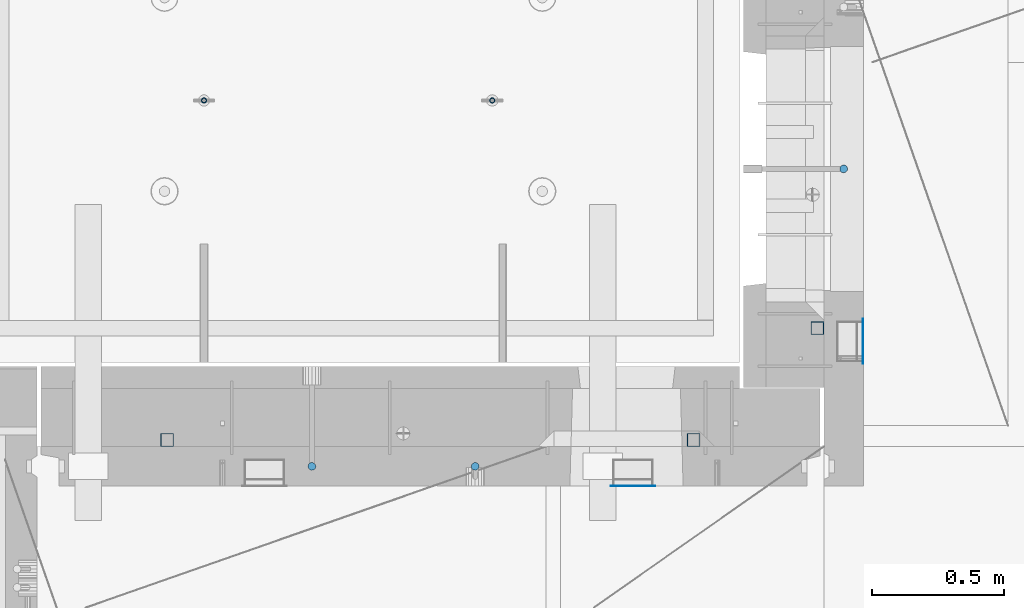
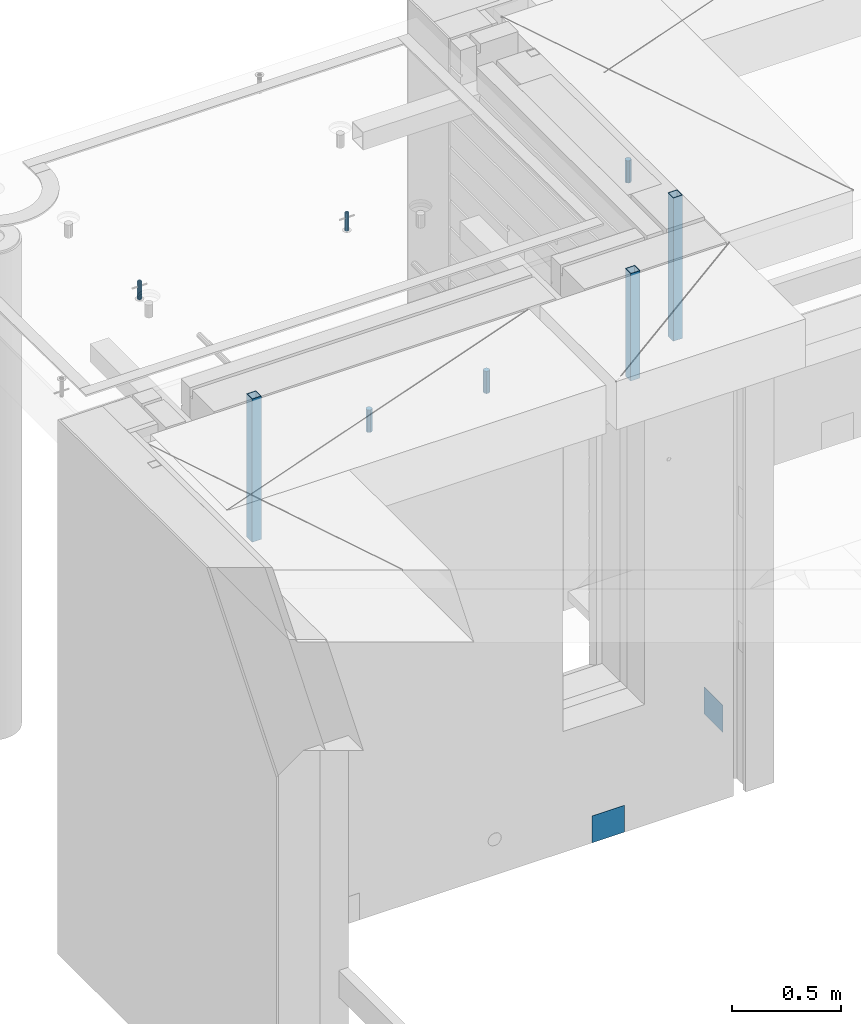
# One storey, part 25 of 334: 10 columns, 10 elements without a shape of their own.
"""IFC2X3 building model written with IfcOpenShell, lengths in millimetres."""

import ifcopenshell
import ifcopenshell.guid

model = None  # the IFC model being written
_history = None  # IfcOwnerHistory: only IFC2X3 demands one
_inside = {}  # id of a spatial element -> (the spatial element, [elements in it])
_under = {}  # id of a project, library or spatial element -> (it, [spatial elements below it])
_declared = {}  # id of a project -> (the project, [libraries it declares])
_typed = {}  # id of a type object -> (the type object, [elements of that type])
_made_of = {}  # id of a material, layer set ... -> (it, [elements and type objects made of it])


def new_model(schema):
    """Start an empty IFC model of exactly this schema.

    Asked for "IFC4X3", IfcOpenShell would pick the latest addendum, in which some entities
    have other attributes; the version numbers below select the first issue.
    IFC2X3 requires an IfcOwnerHistory on every rooted entity: one is made here for all.
    """
    global model, _history
    if schema == "IFC4X3":
        model = ifcopenshell.file(schema_version=(4, 3, 0, 0))
    else:
        model = ifcopenshell.file(schema=schema)
    _inside.clear()
    _under.clear()
    _declared.clear()
    _typed.clear()
    _made_of.clear()
    _history = None
    if model.schema == "IFC2X3":
        org = make("IfcOrganization", Name="unknown")
        user = make(
            "IfcPersonAndOrganization",
            ThePerson=make("IfcPerson", FamilyName="unknown"),
            TheOrganization=org,
        )
        app = make(
            "IfcApplication",
            ApplicationDeveloper=org,
            Version="unknown",
            ApplicationFullName="unknown",
            ApplicationIdentifier="unknown",
        )
        _history = make(
            "IfcOwnerHistory",
            OwningUser=user,
            OwningApplication=app,
            ChangeAction="ADDED",
            CreationDate=0,
        )
    return model


def make(cls, **values):
    """One entity of the class cls with the attributes given. An attribute that is None is left unset."""
    return model.create_entity(
        cls, **{name: value for name, value in values.items() if value is not None}
    )


def rooted(cls, **values):
    """An entity with a GlobalId (a new one), such as an element, a storey or a relation."""
    return make(cls, GlobalId=ifcopenshell.guid.new(), OwnerHistory=_history, **values)


def si_unit(unit_type, name, prefix=None):
    """IfcSIUnit, for example si_unit("LENGTHUNIT", "METRE", prefix="MILLI")."""
    return make("IfcSIUnit", UnitType=unit_type, Prefix=prefix, Name=name)


def assignment(units):
    """IfcUnitAssignment: the units of a project."""
    return None if units is None else make("IfcUnitAssignment", Units=units)


def point(xyz):
    """IfcCartesianPoint."""
    return None if xyz is None else make("IfcCartesianPoint", Coordinates=xyz)


def direction(xyz):
    """IfcDirection."""
    return None if xyz is None else make("IfcDirection", DirectionRatios=xyz)


def frame(location, z_axis=None, x_axis=None):
    """IfcAxis2Placement3D, a coordinate frame: its origin and axes. An axis left out is left unset."""
    return make(
        "IfcAxis2Placement3D",
        Location=point(location),
        Axis=direction(z_axis),
        RefDirection=direction(x_axis),
    )


def origin_with_axes():
    """The frame at (0, 0, 0) with the z axis (0, 0, 1) and the x axis (1, 0, 0) written out."""
    return frame((0.0, 0.0, 0.0), z_axis=(0.0, 0.0, 1.0), x_axis=(1.0, 0.0, 0.0))


def place(relative_to, where):
    """IfcLocalPlacement: puts the frame where relative to a parent placement (None: the world)."""
    return make(
        "IfcLocalPlacement", PlacementRelTo=relative_to, RelativePlacement=where
    )


def context(
    kind, dimensions, precision=None, world=None, true_north=None, identifier=None
):
    """IfcGeometricRepresentationContext, for example the 3D "Model" context."""
    return make(
        "IfcGeometricRepresentationContext",
        ContextIdentifier=identifier,
        ContextType=kind,
        CoordinateSpaceDimension=dimensions,
        Precision=precision,
        WorldCoordinateSystem=world,
        TrueNorth=true_north,
    )


def subcontext(parent, identifier, kind, view, scale=None):
    """IfcGeometricRepresentationSubContext, for example "Body" below "Model"."""
    return make(
        "IfcGeometricRepresentationSubContext",
        ContextIdentifier=identifier,
        ContextType=kind,
        ParentContext=parent,
        TargetScale=scale,
        TargetView=view,
    )


def project(units=None, contexts=None):
    """IfcProject with its units and contexts."""
    return rooted(
        "IfcProject",
        Name="project",
        RepresentationContexts=contexts,
        UnitsInContext=assignment(units),
    )


def spatial(cls, under=None, at=None, **own):
    """A site, building, storey or space (cls), placed at a placement, below another one or the project."""
    s = rooted(cls, ObjectPlacement=at, **own)
    if under is not None:
        _under.setdefault(under.id(), (under, []))[1].append(s)
    return s


def faces_of(points, faces, orient=None, outer=None):
    """IfcFace entities. A face is a list of loops; a loop is a list of indices into points, from 0.

    orient and outer hold one flag for each loop. By default every Orientation is true, the
    first loop of a face is its IfcFaceOuterBound and the others are IfcFaceBound.
    """
    made = []
    for i, loops in enumerate(faces):
        bounds = []
        for j, loop in enumerate(loops):
            is_outer = j == 0 if outer is None else outer[i][j]
            bounds.append(
                make(
                    "IfcFaceOuterBound" if is_outer else "IfcFaceBound",
                    Bound=make("IfcPolyLoop", Polygon=[points[k] for k in loop]),
                    Orientation=True if orient is None else orient[i][j],
                )
            )
        made.append(make("IfcFace", Bounds=bounds))
    return made


def faceted_brep(points, faces, orient=None, outer=None, voids=None):
    """IfcFacetedBrep: a solid bounded by flat faces; with voids (closed shells), ...WithVoids."""
    shared = [point(p) for p in points]
    hull = make("IfcClosedShell", CfsFaces=faces_of(shared, faces, orient, outer))
    if voids is None:
        return make("IfcFacetedBrep", Outer=hull)
    return make(
        "IfcFacetedBrepWithVoids",
        Outer=hull,
        Voids=[
            make(cls, CfsFaces=faces_of(shared, fs, o, b)) for cls, fs, o, b in voids
        ],
    )


def shape(context_of_items, identifier, shape_type, items):
    """IfcShapeRepresentation: the items that make up one representation, for example the "Body"."""
    return make(
        "IfcShapeRepresentation",
        ContextOfItems=context_of_items,
        RepresentationIdentifier=identifier,
        RepresentationType=shape_type,
        Items=items,
    )


def material(Name=None, Category=None):
    """IfcMaterial."""
    return make("IfcMaterial", Name=Name, Category=Category)


def made_of(thing, what):
    """Note that an element or type object is made of a material, layer set ...; save() writes the relation."""
    if what is not None:
        _made_of.setdefault(what.id(), (what, []))[1].append(thing)
    return thing


def type_object(cls, material=None, **own):
    """A type object (cls), such as IfcWallType, which elements share."""
    return made_of(rooted(cls, **own), material)


def element(
    cls,
    number,
    at=None,
    inside=None,
    cuts=None,
    type_object=None,
    material=None,
    context=None,
    identifier="Body",
    shape_type=None,
    held_by="IfcProductDefinitionShape",
    body=None,
    shapes=None,
    **own,
):
    """One element of the class cls, such as IfcWall. Its Tag is "e" and its number.

    at: its placement. inside: the storey or other place that contains it. cuts: it is an
    opening in that element (IfcRelVoidsElement). A single representation is given by context,
    identifier, shape_type and body (its items); several are given by shapes. held_by: the class
    of the entity that holds the representations. save() writes the other relations.
    """
    e = rooted(cls, Tag="e%d" % number, ObjectPlacement=at, **own)
    if body is not None:
        shapes = [shape(context, identifier, shape_type, body)]
    if shapes is not None:
        e.Representation = make(held_by, Representations=shapes)
    if inside is not None:
        _inside.setdefault(inside.id(), (inside, []))[1].append(e)
    if cuts is not None:
        rooted(
            "IfcRelVoidsElement", RelatingBuildingElement=cuts, RelatedOpeningElement=e
        )
    if type_object is not None:
        _typed.setdefault(type_object.id(), (type_object, []))[1].append(e)
    return made_of(e, material)


def aggregate(whole, parts):
    """IfcRelAggregates: a whole, such as a stair, and the parts it consists of."""
    return rooted("IfcRelAggregates", RelatingObject=whole, RelatedObjects=parts)


def save(model, path):
    """Write the relations noted so far, then the file.

    IfcRelAggregates (storeys below a building ...), IfcRelContainedInSpatialStructure (elements
    in a storey), IfcRelDefinesByType, IfcRelAssociatesMaterial and IfcRelDeclares: one each for
    every whole, place, type object, material and project.
    """
    for whole, parts in _under.values():
        aggregate(whole, parts)
    for where, things in _inside.values():
        rooted(
            "IfcRelContainedInSpatialStructure",
            RelatedElements=things,
            RelatingStructure=where,
        )
    for kind, things in _typed.values():
        rooted("IfcRelDefinesByType", RelatedObjects=things, RelatingType=kind)
    for what, things in _made_of.values():
        rooted("IfcRelAssociatesMaterial", RelatedObjects=things, RelatingMaterial=what)
    for by, libraries in _declared.values():
        rooted("IfcRelDeclares", RelatingContext=by, RelatedDefinitions=libraries)
    model.write(path)


model = new_model("IFC2X3")

# Units and contexts
model_context = context("Model", 3, precision=1e-05, world=origin_with_axes())
body_context = subcontext(model_context, "Body", "Model", "MODEL_VIEW")
ifc_project = project(units=[si_unit("LENGTHUNIT", "METRE", prefix="MILLI"), si_unit("AREAUNIT", "SQUARE_METRE"), si_unit("VOLUMEUNIT", "CUBIC_METRE"), si_unit("MASSUNIT", "GRAM", prefix="KILO"), si_unit("TIMEUNIT", "SECOND"), si_unit("PLANEANGLEUNIT", "RADIAN"), si_unit("SOLIDANGLEUNIT", "STERADIAN"), si_unit("THERMODYNAMICTEMPERATUREUNIT", "DEGREE_CELSIUS"), si_unit("LUMINOUSINTENSITYUNIT", "LUMEN")], contexts=[model_context])

# Site, building, storey
site_placement = place(None, origin_with_axes())
site = spatial("IfcSite", under=ifc_project, at=site_placement, CompositionType="ELEMENT")
building_placement = place(site_placement, origin_with_axes())
building = spatial("IfcBuilding", under=site, at=building_placement, CompositionType="ELEMENT")
storey_placement = place(building_placement, origin_with_axes())
storey = spatial("IfcBuildingStorey", under=building, at=storey_placement, Name="3", CompositionType="ELEMENT", Elevation=0.0)

# Assembly, column
assembly_1_placement = place(storey_placement, origin_with_axes())
assembly_1 = element("IfcElementAssembly", 1, at=assembly_1_placement, inside=storey, AssemblyPlace="NOTDEFINED", PredefinedType="REINFORCEMENT_UNIT")
ifc_material_1 = material()
column_type_1 = type_object("IfcColumnType", Name="D30", PredefinedType="NOTDEFINED")
column_1_placement = place(assembly_1_placement, frame((11064.9999999907, 21634.9982799657, 90407.5), z_axis=(1.0, 0.0, 0.0), x_axis=(0.0, 0.0, 1.0)))
column_1 = element("IfcColumn", 2, at=column_1_placement, type_object=column_type_1, material=ifc_material_1, ObjectType="D30", context=body_context, shape_type="Brep", body=[
    faceted_brep([(0.0, -15.0, 0.0), (0.0, -12.9903810567666, -7.5), (125.0, -12.9903810567666, -7.5), (125.0, -15.0, 0.0), (0.0, -7.5, -12.9903810567666), (125.0, -7.5, -12.9903810567666), (0.0, 0.0, -15.0), (125.0, 0.0, -15.0), (0.0, 7.5, -12.9903810567666), (125.0, 7.5, -12.9903810567666), (0.0, 12.9903810567666, -7.5), (125.0, 12.9903810567666, -7.5), (0.0, 15.0, 0.0), (125.0, 15.0, 0.0), (0.0, 12.9903810567666, 7.5), (125.0, 12.9903810567666, 7.5), (0.0, 7.5, 12.9903810567666), (125.0, 7.5, 12.9903810567666), (0.0, 0.0, 15.0), (125.0, 0.0, 15.0), (0.0, -7.5, 12.9903810567666), (125.0, -7.5, 12.9903810567666), (0.0, -12.9903810567666, 7.5), (125.0, -12.9903810567666, 7.5)], [[[0, 1, 2, 3]], [[1, 4, 5, 2]], [[4, 6, 7, 5]], [[6, 8, 9, 7]], [[8, 10, 11, 9]], [[10, 12, 13, 11]], [[12, 14, 15, 13]], [[14, 16, 17, 15]], [[16, 18, 19, 17]], [[18, 20, 21, 19]], [[20, 22, 23, 21]], [[22, 0, 3, 23]], [[5, 7, 9, 11, 13, 15, 17, 19, 21, 23, 3, 2]], [[22, 20, 18, 16, 14, 12, 10, 8, 6, 4, 1, 0]]]),
])

# Assembly, columns
assembly_2_placement = place(storey_placement, origin_with_axes())
assembly_2 = element("IfcElementAssembly", 3, at=assembly_2_placement, inside=storey, AssemblyPlace="NOTDEFINED", PredefinedType="REINFORCEMENT_UNIT")
column_2_placement = place(assembly_2_placement, frame((9665.00172003435, 20504.9951872276, 90407.5), z_axis=(0.0, 1.0, 0.0), x_axis=(0.0, 0.0, 1.0)))
column_2 = element("IfcColumn", 4, at=column_2_placement, type_object=column_type_1, material=ifc_material_1, ObjectType="D30", context=body_context, shape_type="Brep", body=[
    faceted_brep([(0.0, -15.0, 0.0), (0.0, -12.9903810567666, -7.5), (125.0, -12.9903810567666, -7.5), (125.0, -15.0, 0.0), (0.0, -7.5, -12.9903810567666), (125.0, -7.5, -12.9903810567666), (0.0, 0.0, -15.0), (125.0, 0.0, -15.0), (0.0, 7.5, -12.9903810567666), (125.0, 7.5, -12.9903810567666), (0.0, 12.9903810567666, -7.5), (125.0, 12.9903810567666, -7.5), (0.0, 15.0, 0.0), (125.0, 15.0, 0.0), (0.0, 12.9903810567666, 7.5), (125.0, 12.9903810567666, 7.5), (0.0, 7.5, 12.9903810567666), (125.0, 7.5, 12.9903810567666), (0.0, 0.0, 15.0), (125.0, 0.0, 15.0), (0.0, -7.5, 12.9903810567666), (125.0, -7.5, 12.9903810567666), (0.0, -12.9903810567666, 7.5), (125.0, -12.9903810567666, 7.5)], [[[0, 1, 2, 3]], [[1, 4, 5, 2]], [[4, 6, 7, 5]], [[6, 8, 9, 7]], [[8, 10, 11, 9]], [[10, 12, 13, 11]], [[12, 14, 15, 13]], [[14, 16, 17, 15]], [[16, 18, 19, 17]], [[18, 20, 21, 19]], [[20, 22, 23, 21]], [[22, 0, 3, 23]], [[5, 7, 9, 11, 13, 15, 17, 19, 21, 23, 3, 2]], [[22, 20, 18, 16, 14, 12, 10, 8, 6, 4, 1, 0]]]),
])
column_3_placement = place(assembly_2_placement, frame((9045.00366673532, 20504.9951872205, 90407.5), z_axis=(0.0, -1.0, 0.0), x_axis=(0.0, 0.0, 1.0)))
column_3 = element("IfcColumn", 5, at=column_3_placement, type_object=column_type_1, material=ifc_material_1, ObjectType="D30", context=body_context, shape_type="Brep", body=[
    faceted_brep([(0.0, -15.0, 0.0), (0.0, -12.9903810567666, -7.5), (125.0, -12.9903810567666, -7.5), (125.0, -15.0, 0.0), (0.0, -7.5, -12.9903810567666), (125.0, -7.5, -12.9903810567666), (0.0, 0.0, -15.0), (125.0, 0.0, -15.0), (0.0, 7.5, -12.9903810567666), (125.0, 7.5, -12.9903810567666), (0.0, 12.9903810567666, -7.5), (125.0, 12.9903810567666, -7.5), (0.0, 15.0, 0.0), (125.0, 15.0, 0.0), (0.0, 12.9903810567666, 7.5), (125.0, 12.9903810567666, 7.5), (0.0, 7.5, 12.9903810567666), (125.0, 7.5, 12.9903810567666), (0.0, 0.0, 15.0), (125.0, 0.0, 15.0), (0.0, -7.5, 12.9903810567666), (125.0, -7.5, 12.9903810567666), (0.0, -12.9903810567666, 7.5), (125.0, -12.9903810567666, 7.5)], [[[0, 1, 2, 3]], [[1, 4, 5, 2]], [[4, 6, 7, 5]], [[6, 8, 9, 7]], [[8, 10, 11, 9]], [[10, 12, 13, 11]], [[12, 14, 15, 13]], [[14, 16, 17, 15]], [[16, 18, 19, 17]], [[18, 20, 21, 19]], [[20, 22, 23, 21]], [[22, 0, 3, 23]], [[5, 7, 9, 11, 13, 15, 17, 19, 21, 23, 3, 2]], [[22, 20, 18, 16, 14, 12, 10, 8, 6, 4, 1, 0]]]),
])

# Assembly, column
assembly_3_placement = place(assembly_1_placement, origin_with_axes())
assembly_3 = element("IfcElementAssembly", 6, at=assembly_3_placement, Name="Steel Assembly", AssemblyPlace="NOTDEFINED", PredefinedType="NOTDEFINED")
ifc_material_2 = material(Name="Undefined")
column_type_2 = type_object("IfcColumnType", PredefinedType="NOTDEFINED")
column_4_placement = place(assembly_3_placement, frame((11139.0000000031, 20979.9951872276, 87754.9999999969), z_axis=(1.0, 0.0, 0.0), x_axis=(0.0, 0.0, 1.0)))
column_4 = element("IfcColumn", 7, at=column_4_placement, type_object=column_type_2, material=ifc_material_2, Name="SPK2", context=body_context, shape_type="Brep", body=[
    faceted_brep([(0.0, 85.0, -1.0), (0.0, 85.0, 1.0), (150.0, 85.0, 1.0), (150.0, 85.0, -1.0), (0.0, -85.0, 1.0), (150.0, -85.0, 1.0), (0.0, -85.0, -1.0), (150.0, -85.0, -1.0)], [[[0, 1, 2, 3]], [[1, 4, 5, 2]], [[4, 6, 7, 5]], [[6, 0, 3, 7]], [[5, 7, 3, 2]], [[6, 4, 1, 0]]]),
])
aggregate(assembly_3, [column_4])

assembly_4_placement = place(assembly_2_placement, origin_with_axes())
assembly_4 = element("IfcElementAssembly", 8, at=assembly_4_placement, Name="Steel Assembly", AssemblyPlace="NOTDEFINED", PredefinedType="NOTDEFINED")
column_5_placement = place(assembly_4_placement, frame((10265.0, 20430.9951872214, 87755.0), z_axis=(0.0, -1.0, 0.0), x_axis=(0.0, 0.0, 1.0)))
column_5 = element("IfcColumn", 9, at=column_5_placement, type_object=column_type_2, material=ifc_material_2, Name="SPK2", context=body_context, shape_type="Brep", body=[
    faceted_brep([(0.0, 85.0, -1.0), (0.0, 85.0, 1.0), (150.0, 85.0, 1.0), (150.0, 85.0, -1.0), (0.0, -85.0, 1.0), (150.0, -85.0, 1.0), (0.0, -85.0, -1.0), (150.0, -85.0, -1.0)], [[[0, 1, 2, 3]], [[1, 4, 5, 2]], [[4, 6, 7, 5]], [[6, 0, 3, 7]], [[5, 7, 3, 2]], [[6, 4, 1, 0]]]),
])
aggregate(assembly_4, [column_5])

assembly_5_placement = place(assembly_2_placement, origin_with_axes())
assembly_5 = element("IfcElementAssembly", 10, at=assembly_5_placement, Name="Steel Assembly", AssemblyPlace="NOTDEFINED", PredefinedType="RIGID_FRAME")
ifc_material_3 = material(Name="STEEL/S355J2")
column_type_3 = type_object("IfcColumnType", Name="50X50X3", PredefinedType="NOTDEFINED")
column_6_placement = place(assembly_5_placement, frame((8495.0, 20605.0, 89940.0), z_axis=(1.0, 0.0, 0.0), x_axis=(0.0, 0.0, 1.0)))
column_6 = element("IfcColumn", 11, at=column_6_placement, type_object=column_type_3, material=ifc_material_3, ObjectType="50X50X3", context=body_context, shape_type="Brep", body=[
    faceted_brep([(0.0, 22.0, -22.0), (0.0, -22.0, -22.0), (800.0, -22.0, -22.0), (800.0, 22.0, -22.0), (0.0, -22.0, 22.0), (800.0, -22.0, 22.0), (0.0, 22.0, 22.0), (800.0, 22.0, 22.0), (0.0, 25.0, -25.0), (0.0, 25.0, 25.0), (800.0, 25.0, 25.0), (800.0, 25.0, -25.0), (0.0, -25.0, 25.0), (800.0, -25.0, 25.0), (0.0, -25.0, -25.0), (800.0, -25.0, -25.0)], [[[0, 1, 2, 3]], [[1, 4, 5, 2]], [[4, 6, 7, 5]], [[6, 0, 3, 7]], [[8, 9, 10, 11]], [[9, 12, 13, 10]], [[12, 14, 15, 13]], [[14, 8, 11, 15]], [[13, 15, 11, 10], [5, 7, 3, 2]], [[14, 12, 9, 8], [6, 4, 1, 0]]]),
])
aggregate(assembly_5, [column_6])

# Assembly
assembly_6_placement = place(assembly_2_placement, origin_with_axes())
assembly_6 = element("IfcElementAssembly", 12, at=assembly_6_placement, Name="Steel Assembly", AssemblyPlace="NOTDEFINED", PredefinedType="RIGID_FRAME")

aggregate(assembly_2, [column_2, column_3, assembly_4, assembly_5, assembly_6])

# Column
column_7_placement = place(assembly_6_placement, frame((10495.0, 20605.0, 90140.0), z_axis=(1.0, 0.0, 0.0), x_axis=(0.0, 0.0, 1.0)))
column_7 = element("IfcColumn", 13, at=column_7_placement, type_object=column_type_3, material=ifc_material_3, ObjectType="50X50X3", context=body_context, shape_type="Brep", body=[
    faceted_brep([(0.0, 22.0, -22.0), (0.0, -22.0, -22.0), (600.0, -22.0, -22.0), (600.0, 22.0, -22.0), (0.0, -22.0, 22.0), (600.0, -22.0, 22.0), (0.0, 22.0, 22.0), (600.0, 22.0, 22.0), (0.0, 25.0, -25.0), (0.0, 25.0, 25.0), (600.0, 25.0, 25.0), (600.0, 25.0, -25.0), (0.0, -25.0, 25.0), (600.0, -25.0, 25.0), (0.0, -25.0, -25.0), (600.0, -25.0, -25.0)], [[[0, 1, 2, 3]], [[1, 4, 5, 2]], [[4, 6, 7, 5]], [[6, 0, 3, 7]], [[8, 9, 10, 11]], [[9, 12, 13, 10]], [[12, 14, 15, 13]], [[14, 8, 11, 15]], [[13, 15, 11, 10], [5, 7, 3, 2]], [[14, 12, 9, 8], [6, 4, 1, 0]]]),
])

aggregate(assembly_6, [column_7])

# Assembly
assembly_7_placement = place(assembly_1_placement, origin_with_axes())
assembly_7 = element("IfcElementAssembly", 14, at=assembly_7_placement, Name="Steel Assembly", AssemblyPlace="NOTDEFINED", PredefinedType="RIGID_FRAME")

aggregate(assembly_1, [column_1, assembly_3, assembly_7])

# Column
column_8_placement = place(assembly_7_placement, frame((10965.0, 21030.0, 89940.0), z_axis=(1.0, 0.0, 0.0), x_axis=(0.0, 0.0, 1.0)))
column_8 = element("IfcColumn", 15, at=column_8_placement, type_object=column_type_3, material=ifc_material_3, ObjectType="50X50X3", context=body_context, shape_type="Brep", body=[
    faceted_brep([(0.0, 22.0, -22.0), (0.0, -22.0, -22.0), (800.0, -22.0, -22.0), (800.0, 22.0, -22.0), (0.0, -22.0, 22.0), (800.0, -22.0, 22.0), (0.0, 22.0, 22.0), (800.0, 22.0, 22.0), (0.0, 25.0, -25.0), (0.0, 25.0, 25.0), (800.0, 25.0, 25.0), (800.0, 25.0, -25.0), (0.0, -25.0, 25.0), (800.0, -25.0, 25.0), (0.0, -25.0, -25.0), (800.0, -25.0, -25.0)], [[[0, 1, 2, 3]], [[1, 4, 5, 2]], [[4, 6, 7, 5]], [[6, 0, 3, 7]], [[8, 9, 10, 11]], [[9, 12, 13, 10]], [[12, 14, 15, 13]], [[14, 8, 11, 15]], [[13, 15, 11, 10], [5, 7, 3, 2]], [[14, 12, 9, 8], [6, 4, 1, 0]]]),
])

aggregate(assembly_7, [column_8])

# Assemblies, columns
assembly_8_placement = place(storey_placement, origin_with_axes())
assembly_8 = element("IfcElementAssembly", 16, at=assembly_8_placement, inside=storey, AssemblyPlace="NOTDEFINED", PredefinedType="REINFORCEMENT_UNIT")
assembly_9_placement = place(assembly_8_placement, origin_with_axes())
assembly_9 = element("IfcElementAssembly", 17, at=assembly_9_placement, Name="Steel Assembly", AssemblyPlace="NOTDEFINED", PredefinedType="RIGID_FRAME")
ifc_material_4 = material(Name="STEEL/1.4301")
column_type_4 = type_object("IfcColumnType", PredefinedType="NOTDEFINED")
column_9_placement = place(assembly_9_placement, frame((8634.9865866494, 21895.0212615308, 90444.9999983246), z_axis=(-1.60829999983552e-05, -0.999999999870669, 0.0), x_axis=(0.0, 0.0, 1.0)))
column_9 = element("IfcColumn", 18, at=column_9_placement, type_object=column_type_4, material=ifc_material_4, context=body_context, shape_type="Brep", body=[
    faceted_brep([(0.0, -8.0, 0.0), (0.0, -6.92820323027263, 4.0), (100.000000000029, -6.92820323027263, 4.0), (100.000000000029, -7.99999999999636, 0.0), (0.0, -4.0, 6.92820323027627), (100.000000000029, -4.0, 6.92820323027536), (0.0, 0.0, 8.0), (100.000000000029, 3.63797880709171e-12, 8.0), (0.0, 4.0, 6.92820323027627), (100.000000000029, 4.0, 6.92820323027536), (0.0, 6.92820323027263, 4.0), (100.000000000029, 6.92820323027627, 3.99999999999909), (0.0, 8.0, 0.0), (100.000000000029, 8.0, 0.0), (0.0, 6.92820323027263, -4.0), (100.000000000029, 6.92820323027627, -4.00000000000091), (0.0, 4.0, -6.92820323027627), (100.000000000029, 4.00000000000364, -6.92820323027536), (0.0, 0.0, -8.0), (100.000000000029, 3.63797880709171e-12, -8.00000000000091), (0.0, -4.0, -6.92820323027627), (100.000000000029, -3.99999999999636, -6.92820323027627), (0.0, -6.92820323027263, -4.0), (100.000000000029, -6.92820323027263, -4.0), (0.0, -10.4999999999927, -1.45519152283669e-11), (0.0, -9.09326673972828, -5.25000000001455), (100.000000000262, -9.09326673972828, -5.25000000001455), (100.000000000262, -10.4999999999927, -1.45519152283669e-11), (0.0, -5.24999999998545, -9.09326673974283), (100.000000000262, -5.24999999998545, -9.09326673974283), (0.0, 7.27595761418343e-12, -10.5), (100.000000000262, 7.27595761418343e-12, -10.5), (0.0, 5.25000000001455, -9.09326673975738), (100.000000000262, 5.25000000001455, -9.09326673975738), (0.0, 9.09326673975011, -5.25000000001455), (100.000000000262, 9.09326673975011, -5.25000000001455), (0.0, 10.5000000000073, -1.45519152283669e-11), (100.000000000262, 10.5000000000073, -1.45519152283669e-11), (0.0, 9.09326673975011, 5.25), (100.000000000262, 9.09326673975011, 5.25), (0.0, 5.25000000000728, 9.09326673972828), (100.000000000262, 5.25000000000728, 9.09326673972828), (0.0, 1.45519152283669e-11, 10.4999999999854), (100.000000000262, 1.45519152283669e-11, 10.4999999999854), (0.0, -5.24999999999272, 9.09326673972828), (100.000000000262, -5.24999999999272, 9.09326673972828), (0.0, -9.09326673972828, 5.24999999998545), (100.000000000262, -9.09326673972828, 5.24999999998545)], [[[0, 1, 2, 3]], [[1, 4, 5, 2]], [[4, 6, 7, 5]], [[6, 8, 9, 7]], [[8, 10, 11, 9]], [[10, 12, 13, 11]], [[12, 14, 15, 13]], [[14, 16, 17, 15]], [[16, 18, 19, 17]], [[18, 20, 21, 19]], [[20, 22, 23, 21]], [[22, 0, 3, 23]], [[24, 25, 26, 27]], [[25, 28, 29, 26]], [[28, 30, 31, 29]], [[30, 32, 33, 31]], [[32, 34, 35, 33]], [[34, 36, 37, 35]], [[36, 38, 39, 37]], [[38, 40, 41, 39]], [[40, 42, 43, 41]], [[42, 44, 45, 43]], [[44, 46, 47, 45]], [[46, 24, 27, 47]], [[29, 31, 33, 35, 37, 39, 41, 43, 45, 47, 27, 26], [5, 7, 9, 11, 13, 15, 17, 19, 21, 23, 3, 2]], [[46, 44, 42, 40, 38, 36, 34, 32, 30, 28, 25, 24], [22, 20, 18, 16, 14, 12, 10, 8, 6, 4, 1, 0]]]),
])
aggregate(assembly_9, [column_9])
assembly_10_placement = place(assembly_8_placement, origin_with_axes())
assembly_10 = element("IfcElementAssembly", 19, at=assembly_10_placement, Name="Steel Assembly", AssemblyPlace="NOTDEFINED", PredefinedType="RIGID_FRAME")
aggregate(assembly_8, [assembly_9, assembly_10])
column_10_placement = place(assembly_10_placement, frame((9729.98658651215, 21895.0041915483, 90444.9999983246), z_axis=(-1.60829999983552e-05, -0.999999999870669, 0.0), x_axis=(0.0, 0.0, 1.0)))
column_10 = element("IfcColumn", 20, at=column_10_placement, type_object=column_type_4, material=ifc_material_4, context=body_context, shape_type="Brep", body=[
    faceted_brep([(0.0, -8.0, 0.0), (0.0, -6.92820323027263, 4.0), (100.000000000029, -6.92820323027263, 4.0), (100.000000000029, -7.99999999999636, 0.0), (0.0, -4.0, 6.92820323027627), (100.000000000029, -4.0, 6.92820323027536), (0.0, 0.0, 8.0), (100.000000000029, 3.63797880709171e-12, 8.0), (0.0, 4.0, 6.92820323027627), (100.000000000029, 4.0, 6.92820323027536), (0.0, 6.92820323027263, 4.0), (100.000000000029, 6.92820323027627, 3.99999999999909), (0.0, 8.0, 0.0), (100.000000000029, 8.0, 0.0), (0.0, 6.92820323027263, -4.0), (100.000000000029, 6.92820323027627, -4.00000000000091), (0.0, 4.0, -6.92820323027627), (100.000000000029, 4.00000000000364, -6.92820323027536), (0.0, 0.0, -8.0), (100.000000000029, 3.63797880709171e-12, -8.00000000000091), (0.0, -4.0, -6.92820323027627), (100.000000000029, -3.99999999999636, -6.92820323027627), (0.0, -6.92820323027263, -4.0), (100.000000000029, -6.92820323027263, -4.0), (0.0, -10.4999999999927, -1.45519152283669e-11), (0.0, -9.09326673972828, -5.25000000001455), (100.000000000262, -9.09326673972828, -5.25000000001455), (100.000000000262, -10.4999999999927, -1.45519152283669e-11), (0.0, -5.24999999998545, -9.09326673974283), (100.000000000262, -5.24999999998545, -9.09326673974283), (0.0, 7.27595761418343e-12, -10.5), (100.000000000262, 7.27595761418343e-12, -10.5), (0.0, 5.25000000001455, -9.09326673975738), (100.000000000262, 5.25000000001455, -9.09326673975738), (0.0, 9.09326673975011, -5.25000000001455), (100.000000000262, 9.09326673975011, -5.25000000001455), (0.0, 10.5000000000073, -1.45519152283669e-11), (100.000000000262, 10.5000000000073, -1.45519152283669e-11), (0.0, 9.09326673975011, 5.25), (100.000000000262, 9.09326673975011, 5.25), (0.0, 5.25000000000728, 9.09326673972828), (100.000000000262, 5.25000000000728, 9.09326673972828), (0.0, 1.45519152283669e-11, 10.4999999999854), (100.000000000262, 1.45519152283669e-11, 10.4999999999854), (0.0, -5.24999999999272, 9.09326673972828), (100.000000000262, -5.24999999999272, 9.09326673972828), (0.0, -9.09326673972828, 5.24999999998545), (100.000000000262, -9.09326673972828, 5.24999999998545)], [[[0, 1, 2, 3]], [[1, 4, 5, 2]], [[4, 6, 7, 5]], [[6, 8, 9, 7]], [[8, 10, 11, 9]], [[10, 12, 13, 11]], [[12, 14, 15, 13]], [[14, 16, 17, 15]], [[16, 18, 19, 17]], [[18, 20, 21, 19]], [[20, 22, 23, 21]], [[22, 0, 3, 23]], [[24, 25, 26, 27]], [[25, 28, 29, 26]], [[28, 30, 31, 29]], [[30, 32, 33, 31]], [[32, 34, 35, 33]], [[34, 36, 37, 35]], [[36, 38, 39, 37]], [[38, 40, 41, 39]], [[40, 42, 43, 41]], [[42, 44, 45, 43]], [[44, 46, 47, 45]], [[46, 24, 27, 47]], [[29, 31, 33, 35, 37, 39, 41, 43, 45, 47, 27, 26], [5, 7, 9, 11, 13, 15, 17, 19, 21, 23, 3, 2]], [[46, 44, 42, 40, 38, 36, 34, 32, 30, 28, 25, 24], [22, 20, 18, 16, 14, 12, 10, 8, 6, 4, 1, 0]]]),
])
aggregate(assembly_10, [column_10])

save(model, "model.ifc")
